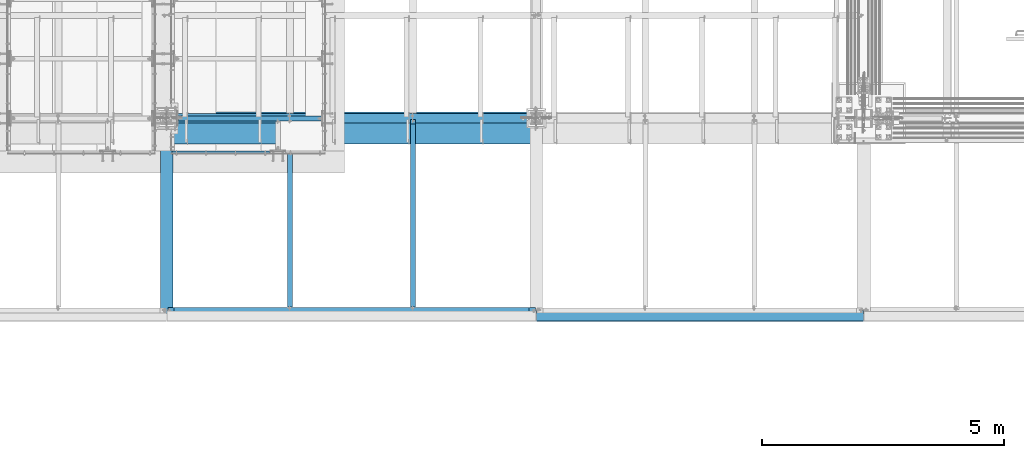
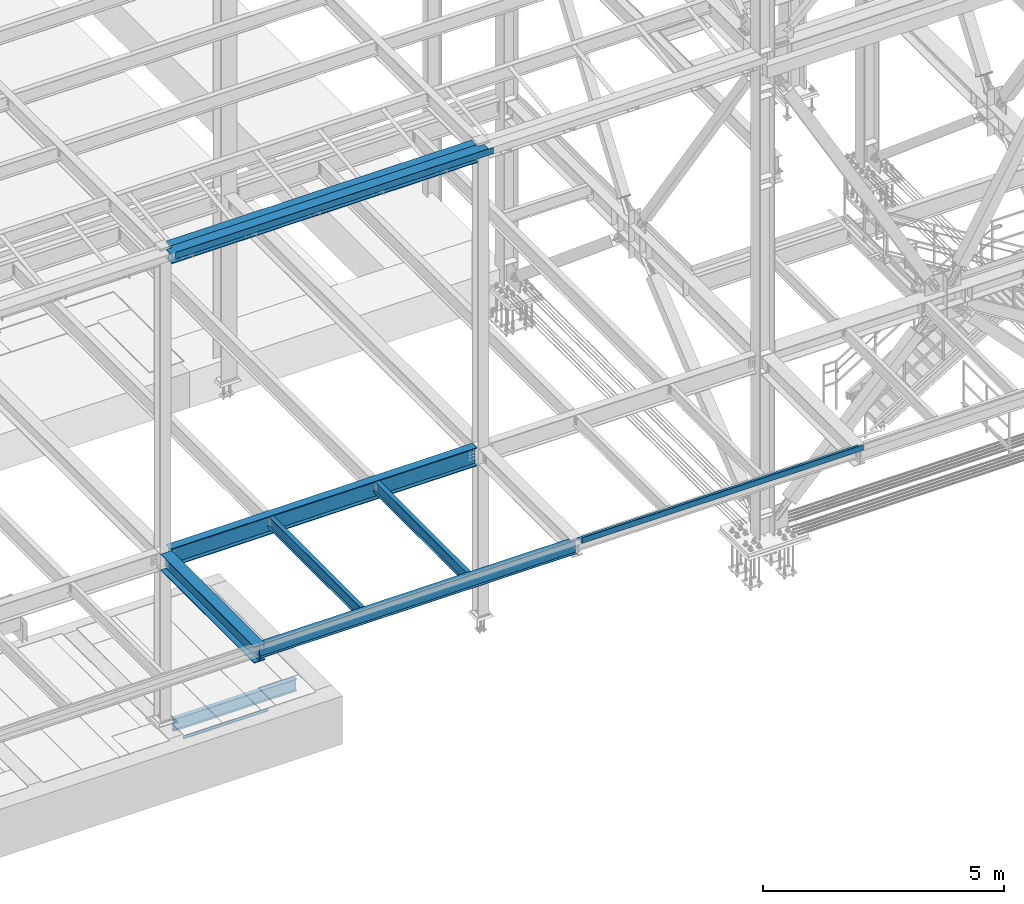
# One storey, part 1752 of 3843: 10 beams, 9 elements without a shape of their own.
"""IFC2X3 building model written with IfcOpenShell, lengths in millimetres."""

from ifc_helpers import new_model, si_unit, frame, origin_with_axes, place, context, subcontext, project, spatial, faceted_brep, material, type_object, element, aggregate, save


model = new_model("IFC2X3")

# Units and contexts
model_context = context("Model", 3, precision=1e-05, world=origin_with_axes())
body_context = subcontext(model_context, "Body", "Model", "MODEL_VIEW")
ifc_project = project(units=[si_unit("LENGTHUNIT", "METRE", prefix="MILLI"), si_unit("AREAUNIT", "SQUARE_METRE"), si_unit("VOLUMEUNIT", "CUBIC_METRE"), si_unit("MASSUNIT", "GRAM", prefix="KILO"), si_unit("TIMEUNIT", "SECOND"), si_unit("PLANEANGLEUNIT", "RADIAN"), si_unit("SOLIDANGLEUNIT", "STERADIAN"), si_unit("THERMODYNAMICTEMPERATUREUNIT", "DEGREE_CELSIUS"), si_unit("LUMINOUSINTENSITYUNIT", "LUMEN")], contexts=[model_context])

# Site, building, storey
site_placement = place(None, origin_with_axes())
site = spatial("IfcSite", under=ifc_project, at=site_placement, CompositionType="ELEMENT")
building_placement = place(site_placement, origin_with_axes())
building = spatial("IfcBuilding", under=site, at=building_placement, Name="Undefined", CompositionType="ELEMENT")
storey_placement = place(building_placement, origin_with_axes())
storey = spatial("IfcBuildingStorey", under=building, at=storey_placement, Name="Undefined", CompositionType="ELEMENT", Elevation=0.0)

# Assembly, beam
assembly_1_placement = place(storey_placement, origin_with_axes())
assembly_1 = element("IfcElementAssembly", 1, at=assembly_1_placement, inside=storey, Name="ANGLE", AssemblyPlace="NOTDEFINED", PredefinedType="RIGID_FRAME")
ifc_material_1 = material(Name="STEEL/A36")
beam_type_1 = type_object("IfcBeamType", Name="L3X3X1/4", PredefinedType="NOTDEFINED")
beam_1_placement = place(assembly_1_placement, frame((64763.6499993328, 14290.6749430412, 30391.1000030518), z_axis=(0.0, 0.0, -1.0), x_axis=(-1.0, 0.0, 0.0)))
beam_1 = element("IfcBeam", 2, at=beam_1_placement, type_object=beam_type_1, material=ifc_material_1, Name="ANGLE", ObjectType="L3X3X1/4", context=body_context, shape_type="Brep", body=[
    faceted_brep([(0.0, 38.0999999999985, -38.0999999999985), (0.0, 38.0999999999985, 38.0999999999985), (2025.64998641385, 38.1000000006406, 38.0999999999985), (2025.64998641385, 38.1000000006406, -38.0999999999985), (0.0, 31.75, 38.0999999999985), (2025.64998641386, 31.7500000006403, 38.0999999999985), (0.0, 31.75, -31.75), (2025.64998641386, 31.7500000006403, -31.75), (0.0, -38.0999999999985, -31.75), (2025.64998641401, -38.0999999993583, -31.75), (0.0, -38.0999999999985, -38.0999999999985), (2025.64998641401, -38.0999999993583, -38.0999999999985)], [[[0, 1, 2, 3]], [[1, 4, 5, 2]], [[4, 6, 7, 5]], [[6, 8, 9, 7]], [[8, 10, 11, 9]], [[10, 0, 3, 11]], [[5, 7, 9, 11, 3, 2]], [[10, 8, 6, 4, 1, 0]]]),
])
aggregate(assembly_1, [beam_1])

assembly_2_placement = place(storey_placement, origin_with_axes())
assembly_2 = element("IfcElementAssembly", 3, at=assembly_2_placement, inside=storey, Name="BEAM", AssemblyPlace="NOTDEFINED", PredefinedType="RIGID_FRAME")
ifc_material_2 = material(Name="STEEL/A992")
beam_type_2 = type_object("IfcBeamType", Name="W12X19", PredefinedType="NOTDEFINED")
beam_2_placement = place(assembly_2_placement, frame((65176.4, 11036.3, 34656.7125), z_axis=(0.0, 0.0, 1.0), x_axis=(0.0, 1.0, 0.0)))
beam_2 = element("IfcBeam", 4, at=beam_2_placement, type_object=beam_type_2, material=ifc_material_2, Name="BEAM", ObjectType="W12X19", context=body_context, shape_type="Brep", body=[
    faceted_brep([(15.8750000000146, -3.17500000000291, -128.587499998961), (15.8750000000146, 3.17500000000291, -128.587499998961), (53.9750001907523, 3.17500000000291, -128.587499998961), (53.9750001907523, -3.17500000000291, -128.587499998961), (58.8350797087915, 3.17500000000291, -129.554229921552), (58.8350797087915, -3.17500000000291, -129.554229921552), (62.9552561769524, 3.17500000000291, -132.307243822026), (62.9552561769524, -3.17500000000291, -132.307243822026), (65.7082700774336, 3.17500000000291, -136.42742029018), (65.7082700774336, -3.17500000000291, -136.42742029018), (66.6750000000175, -3.17500000000291, -141.287499808226), (66.6750000000175, 3.17500000000291, -141.287499808226), (66.6750000000175, 3.17500000000291, -144.462500000001), (66.6750000000175, 50.8000000000029, -144.462500000001), (66.6750000000175, 50.8000000000029, -153.987500000003), (66.6750000000175, -50.8000000000029, -153.987500000003), (66.6750000000175, -50.8000000000029, -144.462500000001), (66.6750000000175, -3.17500000000291, -144.462500000001), (3848.89375, 50.8000000000029, 144.462500000001), (3848.89375, 3.17500000000291, 144.462500000001), (66.6750000000175, 3.17500000000291, 144.462500000001), (66.6750000000175, 50.8000000000029, 144.462500000001), (53.9750001907523, -3.17500000000291, 128.587500001042), (53.9750001907523, 3.17500000000291, 128.587500001042), (15.8750000000146, 3.17500000000291, 128.587500001042), (15.8750000000146, -3.17500000000291, 128.587500001042), (58.8350797087915, -3.17500000000291, 129.554229923633), (58.8350797087915, 3.17500000000291, 129.554229923633), (62.9552561769524, -3.17500000000291, 132.307243824107), (62.9552561769524, 3.17500000000291, 132.307243824107), (65.7082700774336, -3.17500000000291, 136.427420292261), (65.7082700774336, 3.17500000000291, 136.427420292261), (66.6750000000175, -3.17500000000291, 141.287499810307), (66.6750000000175, 3.17500000000291, 141.287499810307), (3848.89375, -50.8000000000029, 153.987500000003), (3848.89375, 50.8000000000029, 153.987500000003), (66.6750000000175, 50.8000000000029, 153.987500000003), (66.6749999999993, -50.8000000000029, 153.89002702928), (3848.89375, -50.8000000000029, 144.462500000001), (66.6750000000175, -50.8000000000029, 144.462500000001), (3848.89375, -3.17500000000291, 144.462500000001), (66.6750000000175, -3.17500000000291, 144.462500000001), (3848.89375, -3.17500000000291, 134.937499809275), (3848.89375, 3.17500000000291, 134.937499809275), (3849.86047992259, -3.17500000000291, 130.077420291229), (3849.86047992259, 3.17500000000291, 130.077420291229), (3852.61349382307, -3.17500000000291, 125.957243823075), (3852.61349382307, 3.17500000000291, 125.957243823075), (3856.73367029122, -3.17500000000291, 123.204229922601), (3856.73367029122, 3.17500000000291, 123.204229922601), (3861.59374980927, -3.17500000000291, 122.23750000001), (3861.59374980927, 3.17500000000291, 122.23750000001), (3944.14375, -3.17500000000291, 122.23750000001), (3944.14375, 3.17500000000291, 122.23750000001), (3944.14375, -3.17500000000291, -144.462500000001), (3944.14375, -50.8000000000029, -144.462500000001), (3944.14375, -50.8000000000029, -153.987500000003), (3944.14375, 50.8000000000029, -153.987500000003), (3944.14375, 50.8000000000029, -144.462500000001), (3944.14375, 3.17500000000291, -144.462500000001), (3944.14375, 3.17500000000291, -114.712500000001), (3944.14375, 3.17500000000291, 115.887499999997), (15.8750000000146, 3.17500000000291, -114.712499998386), (15.8750000000146, 3.17500000000291, 115.887500001612)], [[[0, 1, 2, 3]], [[3, 2, 4, 5]], [[5, 4, 6, 7]], [[7, 6, 8, 9]], [[10, 11, 12, 13, 14, 15, 16, 17]], [[9, 8, 11, 10]], [[18, 19, 20, 21]], [[22, 23, 24, 25]], [[26, 27, 23, 22]], [[28, 29, 27, 26]], [[30, 31, 29, 28]], [[32, 33, 31, 30]], [[34, 35, 36, 37]], [[38, 34, 37, 39]], [[40, 38, 39, 41]], [[37, 36, 21, 20, 33, 32, 41, 39]], [[35, 18, 21, 36]], [[34, 38, 40, 42, 43, 19, 18, 35]], [[44, 45, 43, 42]], [[46, 47, 45, 44]], [[48, 49, 47, 46]], [[50, 51, 49, 48]], [[52, 53, 51, 50]], [[54, 55, 56, 57, 58, 59, 60, 61, 53, 52]], [[55, 54, 17, 16]], [[56, 55, 16, 15]], [[57, 56, 15, 14]], [[58, 57, 14, 13]], [[59, 58, 13, 12]], [[6, 4, 2, 1, 62, 63, 24, 23, 27, 29, 31, 33, 20, 19, 43, 45, 47, 49, 51, 53, 61, 60, 59, 12, 11, 8]], [[25, 24, 63, 62, 1, 0]], [[54, 52, 50, 48, 46, 44, 42, 40, 41, 32, 30, 28, 26, 22, 25, 0, 3, 5, 7, 9, 10, 17]]]),
])
aggregate(assembly_2, [beam_2])

assembly_3_placement = place(storey_placement, origin_with_axes())
assembly_3 = element("IfcElementAssembly", 5, at=assembly_3_placement, inside=storey, Name="BEAM", AssemblyPlace="NOTDEFINED", PredefinedType="RIGID_FRAME")
beam_3_placement = place(assembly_3_placement, frame((67716.4, 11036.3, 34656.7125), z_axis=(0.0, 0.0, 1.0), x_axis=(0.0, 1.0, 0.0)))
beam_3 = element("IfcBeam", 6, at=beam_3_placement, type_object=beam_type_2, material=ifc_material_2, Name="BEAM", ObjectType="W12X19", context=body_context, shape_type="Brep", body=[
    faceted_brep([(15.8750000000146, -3.17500000000291, -128.587499998961), (15.8750000000146, 3.17500000000291, -128.587499998961), (53.9750001907523, 3.17500000000291, -128.587499998961), (53.9750001907523, -3.17500000000291, -128.587499998961), (58.8350797087915, 3.17500000000291, -129.554229921552), (58.8350797087915, -3.17500000000291, -129.554229921552), (62.9552561769524, 3.17500000000291, -132.307243822026), (62.9552561769524, -3.17500000000291, -132.307243822026), (65.7082700774336, 3.17500000000291, -136.42742029018), (65.7082700774336, -3.17500000000291, -136.42742029018), (66.6750000000175, -3.17500000000291, -141.287499808226), (66.6750000000175, 3.17500000000291, -141.287499808226), (66.6750000000175, 3.17500000000291, -144.462500000001), (66.6750000000175, 50.8000000000029, -144.462500000001), (66.6750000000175, 50.8000000000029, -153.987500000003), (66.6750000000175, -50.8000000000029, -153.987500000003), (66.6750000000175, -50.8000000000029, -144.462500000001), (66.6750000000175, -3.17500000000291, -144.462500000001), (3848.89375, 50.8000000000029, 144.462500000001), (3848.89375, 3.17500000000291, 144.462500000001), (66.6750000000175, 3.17500000000291, 144.462500000001), (66.6750000000175, 50.8000000000029, 144.462500000001), (53.9750001907523, -3.17500000000291, 128.587500001042), (53.9750001907523, 3.17500000000291, 128.587500001042), (15.8750000000146, 3.17500000000291, 128.587500001042), (15.8750000000146, -3.17500000000291, 128.587500001042), (58.8350797087915, -3.17500000000291, 129.554229923633), (58.8350797087915, 3.17500000000291, 129.554229923633), (62.9552561769524, -3.17500000000291, 132.307243824107), (62.9552561769524, 3.17500000000291, 132.307243824107), (65.7082700774336, -3.17500000000291, 136.427420292261), (65.7082700774336, 3.17500000000291, 136.427420292261), (66.6750000000175, -3.17500000000291, 141.287499810307), (66.6750000000175, 3.17500000000291, 141.287499810307), (3848.89375, -50.8000000000029, 153.987500000003), (3848.89375, 50.8000000000029, 153.987500000003), (66.6750000000175, 50.8000000000029, 153.987500000003), (66.6749999999993, -50.8000000000029, 153.89002702928), (3848.89375, -50.8000000000029, 144.462500000001), (66.6750000000175, -50.8000000000029, 144.462500000001), (3848.89375, -3.17500000000291, 144.462500000001), (66.6750000000175, -3.17500000000291, 144.462500000001), (3848.89375, -3.17500000000291, 134.937499809275), (3848.89375, 3.17500000000291, 134.937499809275), (3849.86047992259, -3.17500000000291, 130.077420291229), (3849.86047992259, 3.17500000000291, 130.077420291229), (3852.61349382307, -3.17500000000291, 125.957243823075), (3852.61349382307, 3.17500000000291, 125.957243823075), (3856.73367029122, -3.17500000000291, 123.204229922601), (3856.73367029122, 3.17500000000291, 123.204229922601), (3861.59374980927, -3.17500000000291, 122.23750000001), (3861.59374980927, 3.17500000000291, 122.23750000001), (3944.14375, -3.17500000000291, 122.23750000001), (3944.14375, 3.17500000000291, 122.23750000001), (3944.14375, -3.17500000000291, -144.462500000001), (3944.14375, -50.8000000000029, -144.462500000001), (3944.14375, -50.8000000000029, -153.987500000003), (3944.14375, 50.8000000000029, -153.987500000003), (3944.14375, 50.8000000000029, -144.462500000001), (3944.14375, 3.17500000000291, -144.462500000001), (3944.14375, 3.17500000000291, -114.712500000001), (3944.14375, 3.17500000000291, 115.887499999997), (15.8750000000146, 3.17500000000291, -114.712499998386), (15.8750000000146, 3.17500000000291, 115.887500001612)], [[[0, 1, 2, 3]], [[3, 2, 4, 5]], [[5, 4, 6, 7]], [[7, 6, 8, 9]], [[10, 11, 12, 13, 14, 15, 16, 17]], [[9, 8, 11, 10]], [[18, 19, 20, 21]], [[22, 23, 24, 25]], [[26, 27, 23, 22]], [[28, 29, 27, 26]], [[30, 31, 29, 28]], [[32, 33, 31, 30]], [[34, 35, 36, 37]], [[38, 34, 37, 39]], [[40, 38, 39, 41]], [[37, 36, 21, 20, 33, 32, 41, 39]], [[35, 18, 21, 36]], [[34, 38, 40, 42, 43, 19, 18, 35]], [[44, 45, 43, 42]], [[46, 47, 45, 44]], [[48, 49, 47, 46]], [[50, 51, 49, 48]], [[52, 53, 51, 50]], [[54, 55, 56, 57, 58, 59, 60, 61, 53, 52]], [[55, 54, 17, 16]], [[56, 55, 16, 15]], [[57, 56, 15, 14]], [[58, 57, 14, 13]], [[59, 58, 13, 12]], [[6, 4, 2, 1, 62, 63, 24, 23, 27, 29, 31, 33, 20, 19, 43, 45, 47, 49, 51, 53, 61, 60, 59, 12, 11, 8]], [[25, 24, 63, 62, 1, 0]], [[54, 52, 50, 48, 46, 44, 42, 40, 41, 32, 30, 28, 26, 22, 25, 0, 3, 5, 7, 9, 10, 17]]]),
])
aggregate(assembly_3, [beam_3])

assembly_4_placement = place(storey_placement, origin_with_axes())
assembly_4 = element("IfcElementAssembly", 7, at=assembly_4_placement, inside=storey, Name="BEAM", AssemblyPlace="NOTDEFINED", PredefinedType="RIGID_FRAME")
beam_type_3 = type_object("IfcBeamType", Name="W18X65", PredefinedType="NOTDEFINED")
beam_4_placement = place(assembly_4_placement, frame((62636.4, 14998.7, 34577.3375), z_axis=(0.0, 0.0, 1.0), x_axis=(1.0, 0.0, 0.0)))
beam_4 = element("IfcBeam", 8, at=beam_4_placement, type_object=beam_type_3, material=ifc_material_2, Name="BEAM", ObjectType="W18X65", context=body_context, shape_type="Brep", body=[
    faceted_brep([(141.287499999991, 96.8374999999996, -233.362500000003), (141.287499999991, 96.8374999999996, -214.3125), (7478.71250000001, 96.8374999999996, -214.3125), (7478.71250000001, 96.8374999999996, -233.362500000003), (141.287499999991, 5.55624999999964, -214.3125), (7478.71250000001, 5.55624999999964, -214.3125), (141.287499999991, 5.55624999999964, 214.3125), (7478.71250000001, 5.55624999999964, 214.3125), (141.287499999991, 96.8374999999996, 214.3125), (7478.71250000001, 96.8374999999996, 214.3125), (141.287499999991, 96.8374999999996, 233.362500000003), (7478.71250000001, 96.8374999999996, 233.362500000003), (141.287499999991, -96.8374999999996, 233.362500000003), (7478.71250000001, -96.8374999999996, 233.362500000003), (141.287499999991, -96.8374999999996, 214.3125), (7478.71250000001, -96.8374999999996, 214.3125), (141.287499999991, -5.55624999999964, 214.3125), (7478.71250000001, -5.55624999999964, 214.3125), (141.287499999991, -5.55624999999964, -214.3125), (7478.71250000001, -5.55624999999964, -214.3125), (141.287499999991, -96.8374999999996, -214.3125), (7478.71250000001, -96.8374999999996, -214.3125), (141.287499999991, -96.8374999999996, -233.362500000003), (7478.71250000001, -96.8374999999996, -233.362500000003)], [[[0, 1, 2, 3]], [[1, 4, 5, 2]], [[4, 6, 7, 5]], [[6, 8, 9, 7]], [[8, 10, 11, 9]], [[10, 12, 13, 11]], [[12, 14, 15, 13]], [[14, 16, 17, 15]], [[16, 18, 19, 17]], [[18, 20, 21, 19]], [[20, 22, 23, 21]], [[22, 0, 3, 23]], [[5, 7, 9, 11, 13, 15, 17, 19, 21, 23, 3, 2]], [[22, 20, 18, 16, 14, 12, 10, 8, 6, 4, 1, 0]]]),
])
aggregate(assembly_4, [beam_4])

assembly_5_placement = place(storey_placement, origin_with_axes())
assembly_5 = element("IfcElementAssembly", 9, at=assembly_5_placement, inside=storey, Name="BEAM", AssemblyPlace="NOTDEFINED", PredefinedType="RIGID_FRAME")
beam_type_4 = type_object("IfcBeamType", PredefinedType="NOTDEFINED")
beam_5_placement = place(assembly_5_placement, frame((66446.4, 14919.325, 42471.975), z_axis=(-1.0, 0.0, 0.0), x_axis=(0.0, -1.0, 0.0)))
beam_5 = element("IfcBeam", 10, at=beam_5_placement, type_object=beam_type_4, material=ifc_material_1, Name="BENT_PLATE", context=body_context, shape_type="Brep", body=[
    faceted_brep([(63.5, -3.17500000000291, 3668.7125), (63.5, 3.17500000000291, 3668.7125), (0.0, 3.17500000000291, 3668.713), (0.0, -3.17500000000291, 3668.713), (63.5, -3.17500000000291, 3806.8255), (63.5, 3.17500000000291, 3806.8255), (0.0, -3.17500000000291, -3668.71250000001), (0.0, 3.17500000000291, -3668.71250000001), (63.4999999999927, 3.17500000000291, -3668.71250000002), (63.4999999999927, -3.17500000000291, -3668.71250000002), (63.5000000000073, 3.17500000000291, -3806.82550000001), (63.5000000000073, -3.17500000000291, -3806.82550000001), (447.674999999997, 3.17500000000291, -3806.82550000001), (447.674999999997, 161.924999999996, -3806.82550000001), (454.024999999996, 161.924999999996, -3806.82550000001), (454.024999999996, -3.17500000000291, -3806.82550000001), (447.674999999997, 3.17500000000291, 3806.8255), (447.674999999997, 161.924999999996, 3806.8255), (454.024999999996, 161.924999999996, 3806.8255), (454.024999999996, -3.17500000000291, 3806.8255)], [[[0, 1, 2, 3]], [[4, 5, 1, 0]], [[6, 7, 8, 9]], [[9, 8, 10, 11]], [[12, 13, 14, 15, 11, 10]], [[12, 16, 17, 13]], [[18, 14, 13, 17]], [[19, 15, 14, 18]], [[3, 6, 9, 11, 15, 19, 4, 0]], [[7, 6, 3, 2]], [[16, 12, 10, 8, 7, 2, 1, 5]], [[19, 18, 17, 16, 5, 4]]]),
])

assembly_6_placement = place(storey_placement, origin_with_axes())
assembly_6 = element("IfcElementAssembly", 11, at=assembly_6_placement, inside=storey, Name="BEAM", AssemblyPlace="NOTDEFINED", PredefinedType="RIGID_FRAME")
beam_type_5 = type_object("IfcBeamType", PredefinedType="NOTDEFINED")
beam_6_placement = place(assembly_6_placement, frame((73634.20325, 11036.3, 34813.875), z_axis=(-1.0, 0.0, 0.0), x_axis=(0.0, -1.0, 0.0)))
beam_6 = element("IfcBeam", 12, at=beam_6_placement, type_object=beam_type_5, material=ifc_material_1, Name="BENT_PLATE", context=body_context, shape_type="Brep", body=[
    faceted_brep([(0.0, -3.17500000000291, -3374.628), (0.0, -3.17500000000291, 3374.628), (0.0, 3.17500000000291, 3374.628), (0.0, 3.17500000000291, -3374.628), (222.249993896483, 3.17500000000291, 3374.628), (222.249993896483, 3.17500000000291, -3374.628), (228.599993896481, -3.17500000000291, -3374.628), (228.599993896481, -3.17500000000291, 3374.628), (222.249993896483, 136.524996948239, 3374.628), (222.249993896483, 136.524996948239, -3374.628), (228.599993896481, 136.524996948239, 3374.628), (228.599993896481, 136.524996948239, -3374.628)], [[[0, 1, 2, 3]], [[3, 2, 4, 5]], [[1, 0, 6, 7]], [[5, 4, 8, 9]], [[4, 2, 1, 7, 10, 8]], [[7, 6, 11, 10]], [[6, 0, 3, 5, 9, 11]], [[10, 11, 9, 8]]]),
])
aggregate(assembly_6, [beam_6])

# Beam
beam_type_6 = type_object("IfcBeamType", Name="W16X67", PredefinedType="NOTDEFINED")
beam_7_placement = place(assembly_5_placement, frame((62636.4, 14998.7, 42260.8375), z_axis=(0.0, 0.0, 1.0), x_axis=(1.0, 0.0, 0.0)))
beam_7 = element("IfcBeam", 13, at=beam_7_placement, type_object=beam_type_6, material=ifc_material_2, Name="BEAM", ObjectType="W16X67", context=body_context, shape_type="Brep", body=[
    faceted_brep([(141.287500000006, 100.012500000001, -207.962500000001), (141.287500000006, -100.012500000001, -207.962500000001), (141.287500000035, -130.174999999999, -207.962500000001), (141.287500000035, -130.174999999999, -190.5), (141.287500000006, -100.012500000001, -190.5), (141.287500000035, -4.76250000000073, -190.5), (141.287500000035, -4.76250000000073, 190.5), (141.287500000006, -100.012500000001, 190.5), (141.287500000035, -130.174999999999, 190.5), (141.287500000035, -130.174999999999, 207.962500000001), (141.287500000006, -100.012500000001, 207.962500000001), (141.287500000006, 100.012500000001, 207.962500000001), (141.287500000035, 130.174999999999, 207.962500000001), (141.287500000035, 130.174999999999, 190.5), (141.287500000006, 100.012500000001, 190.5), (141.287500000035, 4.76250000000073, 190.5), (141.287500000035, 4.76250000000073, 170.602500000001), (141.287500000035, 4.76250000000073, -148.377499999995), (141.287500000035, 4.76250000000073, -190.5), (141.287500000006, 100.012500000001, -190.5), (141.287500000035, 130.174999999999, -190.5), (141.287500000035, 130.174999999999, -207.962500000001), (7478.71250000003, -130.174999999999, -207.962500000001), (7478.71250000003, -130.174999999999, -190.5), (7478.71250000003, -100.012500000004, -190.5), (7478.71250000003, -4.76250000000073, -190.5), (7478.71250000003, -4.76250000000073, 190.5), (7478.71250000003, -100.012500000004, 190.5), (7478.71250000003, -130.174999999999, 190.5), (7478.71250000003, -130.174999999999, 207.962500000001), (7478.71250000003, -100.012500000004, 207.962500000001), (7478.71250000003, 100.012499999997, 207.962500000001), (7478.71250000003, 130.174999999999, 207.962500000001), (7478.71250000003, 130.174999999999, 190.5), (7478.71250000003, 100.012499999997, 190.5), (7478.71250000003, 4.76250000000073, 190.5), (7478.71250000003, 4.76250000000073, 170.602500000001), (7478.71250000003, 4.76250000000073, -148.377499999995), (7478.71250000003, 4.76250000000073, -190.5), (7478.71250000003, 100.012499999997, -190.5), (7478.71250000003, 130.174999999999, -190.5), (7478.71250000003, 130.174999999999, -207.962500000001), (7478.71250000003, -100.012500000004, -207.962500000001), (7478.71250000003, 100.012499999997, -207.962500000001)], [[[0, 1, 2, 3, 4, 5, 6, 7, 8, 9, 10, 11, 12, 13, 14, 15, 16, 17, 18, 19, 20, 21]], [[3, 2, 22, 23]], [[5, 4, 3, 23, 24, 25]], [[6, 5, 25, 26]], [[8, 7, 6, 26, 27, 28]], [[9, 8, 28, 29]], [[12, 11, 10, 9, 29, 30, 31, 32]], [[13, 12, 32, 33]], [[15, 14, 13, 33, 34, 35]], [[18, 17, 16, 15, 35, 36, 37, 38]], [[20, 19, 18, 38, 39, 40]], [[21, 20, 40, 41]], [[39, 38, 37, 36, 35, 34, 33, 32, 31, 30, 29, 28, 27, 26, 25, 24, 23, 22, 42, 43, 41, 40]], [[2, 1, 0, 21, 41, 43, 42, 22]]]),
])

aggregate(assembly_5, [beam_5, beam_7])

# Assembly, beam
assembly_7_placement = place(storey_placement, origin_with_axes())
assembly_7 = element("IfcElementAssembly", 14, at=assembly_7_placement, inside=storey, Name="BEAM", AssemblyPlace="NOTDEFINED", PredefinedType="RIGID_FRAME")
beam_type_7 = type_object("IfcBeamType", Name="W14X22", PredefinedType="NOTDEFINED")
beam_8_placement = place(assembly_7_placement, frame((62636.4, 11036.3, 34636.075), z_axis=(0.0, 0.0, 1.0), x_axis=(1.0, 0.0, 0.0)))
beam_8 = element("IfcBeam", 15, at=beam_8_placement, type_object=beam_type_7, material=ifc_material_2, Name="BEAM", ObjectType="W14X22", context=body_context, shape_type="Brep", body=[
    faceted_brep([(7474.74375000001, -63.5, 174.625), (7474.74375000001, -63.5, 166.6875), (7474.74375000001, -3.17499999999927, 166.6875), (7474.74375000001, -3.17499999999927, 155.574999809272), (7474.74375000001, 3.17499999999927, 155.574999809272), (7474.74375000001, 3.17499999999927, 166.6875), (7474.74375000001, 63.5, 166.6875), (7474.74375000001, 63.5, 174.625), (7475.71047992259, -3.17499999999927, 150.714920291226), (7475.71047992259, 3.17499999999927, 150.714920291226), (7478.46349382307, -3.17499999999927, 146.594743823072), (7478.46349382307, 3.17499999999927, 146.594743823072), (7482.58367029123, -3.17499999999927, 143.841729922598), (7482.58367029123, 3.17499999999927, 143.841729922598), (7487.44374980927, -3.17499999999927, 142.875000000007), (7487.44374980927, 3.17499999999927, 142.875000000007), (7601.74375000001, -3.17499999999927, 142.875000000007), (7601.74375000001, 3.17499999999927, 142.875000000007), (145.256250000006, -63.5, 174.625), (145.256250000006, 63.5, 174.625), (145.256250000006, 63.5, 166.6875), (145.256250000006, 3.17499999999927, 166.6875), (145.256250000006, 3.17499999999927, 155.574999809272), (145.256250000006, -3.17499999999927, 155.574999809272), (145.256250000006, -3.17499999999927, 166.6875), (145.256250000006, -63.5, 166.6875), (144.289520077415, 3.17499999999927, 150.714920291226), (144.289520077415, -3.17499999999927, 150.714920291226), (141.536506176941, 3.17499999999927, 146.594743823072), (141.536506176941, -3.17499999999927, 146.594743823072), (137.416329708787, 3.17499999999927, 143.841729922598), (137.416329708787, -3.17499999999927, 143.841729922598), (132.556250190741, 3.17499999999927, 142.875000000007), (132.556250190741, -3.17499999999927, 142.875000000007), (18.2562500000058, 3.17499999999927, 142.875000000007), (18.2562500000058, -3.17499999999927, 142.875000000007), (18.2562500000058, 3.17499999999927, 136.525000000001), (18.2562500000058, 3.17499999999927, -94.0749999999971), (18.2562500000058, 3.17499999999927, -166.6875), (18.2562500000058, 63.5, -166.6875), (18.2562500000058, 63.5, -174.625), (18.2562500000058, -63.5, -174.625), (18.2562500000058, -63.5, -166.6875), (18.2562500000058, -3.17499999999927, -166.6875), (7601.74375000001, 3.17499999999927, -166.6875), (7601.74375000001, 63.5, -166.6875), (7601.74375000001, 63.5, -174.625), (7601.74375000001, -63.5, -174.625), (7601.74375000001, -63.5, -166.6875), (7601.74375000001, -3.17499999999927, -166.6875), (7601.74375000001, 3.17499999999927, 136.525000000001), (7601.74375000001, 3.17499999999927, -94.0749999999971)], [[[0, 1, 2, 3, 4, 5, 6, 7]], [[8, 9, 4, 3]], [[10, 11, 9, 8]], [[12, 13, 11, 10]], [[14, 15, 13, 12]], [[16, 17, 15, 14]], [[18, 19, 20, 21, 22, 23, 24, 25]], [[23, 22, 26, 27]], [[27, 26, 28, 29]], [[29, 28, 30, 31]], [[31, 30, 32, 33]], [[33, 32, 34, 35]], [[36, 37, 38, 39, 40, 41, 42, 43, 35, 34]], [[39, 38, 44, 45]], [[40, 39, 45, 46]], [[41, 40, 46, 47]], [[42, 41, 47, 48]], [[43, 42, 48, 49]], [[12, 10, 8, 3, 2, 24, 23, 27, 29, 31, 33, 35, 43, 49, 16, 14]], [[25, 24, 2, 1]], [[18, 25, 1, 0]], [[19, 18, 0, 7]], [[20, 19, 7, 6]], [[21, 20, 6, 5]], [[50, 51, 44, 38, 37, 36, 34, 32, 30, 28, 26, 22, 21, 5, 4, 9, 11, 13, 15, 17]], [[49, 48, 47, 46, 45, 44, 51, 50, 17, 16]]]),
])
aggregate(assembly_7, [beam_8])

assembly_8_placement = place(storey_placement, origin_with_axes())
assembly_8 = element("IfcElementAssembly", 16, at=assembly_8_placement, inside=storey, Name="BEAM", AssemblyPlace="NOTDEFINED", PredefinedType="RIGID_FRAME")
beam_type_8 = type_object("IfcBeamType", Name="W12X22", PredefinedType="NOTDEFINED")
beam_9_placement = place(assembly_8_placement, frame((62941.2, 14998.7, 30273.625), z_axis=(0.0, 0.0, 1.0), x_axis=(1.0, 0.0, 0.0)))
beam_9 = element("IfcBeam", 17, at=beam_9_placement, type_object=beam_type_8, material=ifc_material_2, Name="BEAM", ObjectType="W12X22", context=body_context, shape_type="Brep", body=[
    faceted_brep([(-63.4999969482451, 50.7999999999993, -155.575000000001), (-63.4999969482451, 50.7999999999993, -144.462500000001), (2889.25000000001, 50.7999999999993, -144.462500000001), (2889.25000000001, 50.7999999999993, -155.575000000001), (-63.4999969482451, 3.17499999999927, -144.462500000001), (2889.25000000001, 3.17499999999927, -144.462500000001), (-63.4999969482451, 3.17499999999927, 144.462500000001), (2889.25000000001, 3.17499999999927, 144.462500000001), (-63.4999969482451, 50.7999999999993, 144.462500000001), (2889.25000000001, 50.7999999999993, 144.462500000001), (-63.4999969482451, 50.7999999999993, 155.575000000001), (2889.25000000001, 50.7999999999993, 155.575000000001), (-63.4999969482451, -50.7999999999993, 155.575000000001), (2889.25000000001, -50.7999999999993, 155.575000000001), (-63.4999969482451, -50.7999999999993, 144.462500000001), (2889.25000000001, -50.7999999999993, 144.462500000001), (-63.4999969482451, -3.17499999999927, 144.462500000001), (2889.25000000001, -3.17499999999927, 144.462500000001), (-63.4999969482451, -3.17499999999927, -144.462500000001), (2889.25000000001, -3.17499999999927, -144.462500000001), (-63.4999969482451, -50.7999999999993, -144.462500000001), (2889.25000000001, -50.7999999999993, -144.462500000001), (-63.4999969482451, -50.7999999999993, -155.575000000001), (2889.25000000001, -50.7999999999993, -155.575000000001)], [[[0, 1, 2, 3]], [[1, 4, 5, 2]], [[4, 6, 7, 5]], [[6, 8, 9, 7]], [[8, 10, 11, 9]], [[10, 12, 13, 11]], [[12, 14, 15, 13]], [[14, 16, 17, 15]], [[16, 18, 19, 17]], [[18, 20, 21, 19]], [[20, 22, 23, 21]], [[22, 0, 3, 23]], [[5, 7, 9, 11, 13, 15, 17, 19, 21, 23, 3, 2]], [[22, 20, 18, 16, 14, 12, 10, 8, 6, 4, 1, 0]]]),
])
aggregate(assembly_8, [beam_9])

assembly_9_placement = place(storey_placement, origin_with_axes())
assembly_9 = element("IfcElementAssembly", 18, at=assembly_9_placement, inside=storey, Name="BEAM", AssemblyPlace="NOTDEFINED", PredefinedType="RIGID_FRAME")
beam_type_9 = type_object("IfcBeamType", Name="W16X77", PredefinedType="NOTDEFINED")
beam_10_placement = place(assembly_9_placement, frame((62636.4, 10972.8, 34601.15), z_axis=(0.0, 0.0, 1.0), x_axis=(0.0, 1.0, 0.0)))
beam_10 = element("IfcBeam", 19, at=beam_10_placement, type_object=beam_type_9, material=ifc_material_2, Name="BEAM", ObjectType="W16X77", context=body_context, shape_type="Brep", body=[
    faceted_brep([(3886.2, -130.175000000003, 190.5), (3886.2, -5.55624999999418, 190.5), (3886.2, 5.55624999999418, 190.5), (3886.2, 130.175000000003, 190.5), (3875.20141803238, 130.175000000003, 209.550000000003), (3875.20141803238, -130.175000000003, 209.550000000003), (0.0, -130.175000000003, -209.550000000003), (0.0, -130.175000000003, -190.5), (0.0, -5.55624999999418, -190.5), (0.0, -5.55624999999418, 190.5), (0.0, -130.175000000003, 190.5), (0.0, -130.175000000003, 209.550000000003), (0.0, 130.175000000003, 209.550000000003), (0.0, 130.175000000003, 190.5), (0.0, 5.55624999999418, 190.5), (0.0, 5.55624999999418, -190.5), (0.0, 130.175000000003, -190.5), (0.0, 130.175000000003, -209.550000000003), (3886.2, -5.55624999999418, 190.102999899296), (3886.2, 5.55624999999418, 190.102999899296), (3860.79999847412, -5.55624999999418, 190.102999496463), (3860.79999847412, 5.55624999999418, 190.102999496463), (3814.20655163457, -5.55624999999418, 180.79025946014), (3814.20655163457, 5.55624999999418, 180.79025946014), (3809.33324643477, -5.55624999999418, 178.180215038927), (3809.33324643477, 5.55624999999418, 178.180215038927), (3806.73040363465, -5.55624999999418, 173.303059637583), (3806.73040363465, 5.55624999999418, 173.303059637583), (3807.27480549495, -5.55624999999418, 167.801690529304), (3807.27480549495, 5.55624999999418, 167.801690529304), (3810.78306718207, -5.55624999999418, 163.52927489108), (3810.78306718207, 5.55624999999418, 163.52927489108), (3816.07341098232, -5.55624999999418, 161.925000000003), (3816.07341098232, 5.55624999999418, 161.925000000003), (3883.02500000001, -5.55624999999418, 161.925000000003), (3883.02500000001, 5.55624999999418, 161.925000000003), (3883.02500000001, -5.55624999999418, -161.925000000003), (3883.02500000001, 5.55624999999418, -161.925000000003), (3817.31641075723, -5.55624999999418, -161.925000000003), (3817.31641075723, 5.55624999999418, -161.925000000003), (3812.02606697345, -5.55624999999418, -163.529274880071), (3812.02606697345, 5.55624999999418, -163.529274880071), (3808.51780528504, -5.55624999999418, -167.801690492699), (3808.51780528504, 5.55624999999418, -167.801690492699), (3807.97340339799, -5.55624999999418, -173.303059579281), (3807.97340339799, 5.55624999999418, -173.303059579281), (3810.57624615368, -5.55624999999418, -178.180214982844), (3810.57624615368, 5.55624999999418, -178.180214982844), (3815.44955131233, -5.55624999999418, -180.790259440721), (3815.44955131233, 5.55624999999418, -180.790259440721), (3862.04299572754, -5.55624999999418, -190.102999496463), (3862.04299572754, 5.55624999999418, -190.102999496463), (3874.97220034301, -5.55624999999418, -190.102999709867), (3874.97220034301, 5.55624999999418, -190.102999709867), (3875.20140175344, 5.55624999999418, -190.5), (3875.20140175344, 130.175000000003, -190.5), (3886.2, 130.175000000003, -209.550000000003), (3886.2, -130.175000000003, -209.550000000003), (3875.20140175344, -130.175000000003, -190.5), (3875.20140175344, -5.55624999999418, -190.5)], [[[0, 1, 2, 3, 4, 5]], [[6, 7, 8, 9, 10, 11, 12, 13, 14, 15, 16, 17]], [[11, 10, 0, 5]], [[12, 11, 5, 4]], [[13, 12, 4, 3]], [[14, 13, 3, 2]], [[18, 19, 2, 1]], [[20, 21, 19, 18]], [[22, 23, 21, 20]], [[24, 25, 23, 22]], [[26, 27, 25, 24]], [[28, 29, 27, 26]], [[30, 31, 29, 28]], [[32, 33, 31, 30]], [[33, 32, 34, 35]], [[34, 36, 37, 35]], [[38, 39, 37, 36]], [[40, 41, 39, 38]], [[42, 43, 41, 40]], [[44, 45, 43, 42]], [[46, 47, 45, 44]], [[48, 49, 47, 46]], [[50, 51, 49, 48]], [[51, 50, 52, 53]], [[15, 14, 2, 19, 21, 23, 25, 27, 29, 31, 33, 35, 37, 39, 41, 43, 45, 47, 49, 51, 53, 54]], [[16, 15, 54, 55]], [[17, 16, 55, 56]], [[6, 17, 56, 57]], [[7, 6, 57, 58]], [[8, 7, 58, 59]], [[57, 56, 55, 54, 53, 52, 59, 58]], [[50, 48, 46, 44, 42, 40, 38, 36, 34, 32, 30, 28, 26, 24, 22, 20, 18, 1, 9, 8, 59, 52]], [[10, 9, 1, 0]]]),
])
aggregate(assembly_9, [beam_10])

save(model, "model.ifc")
